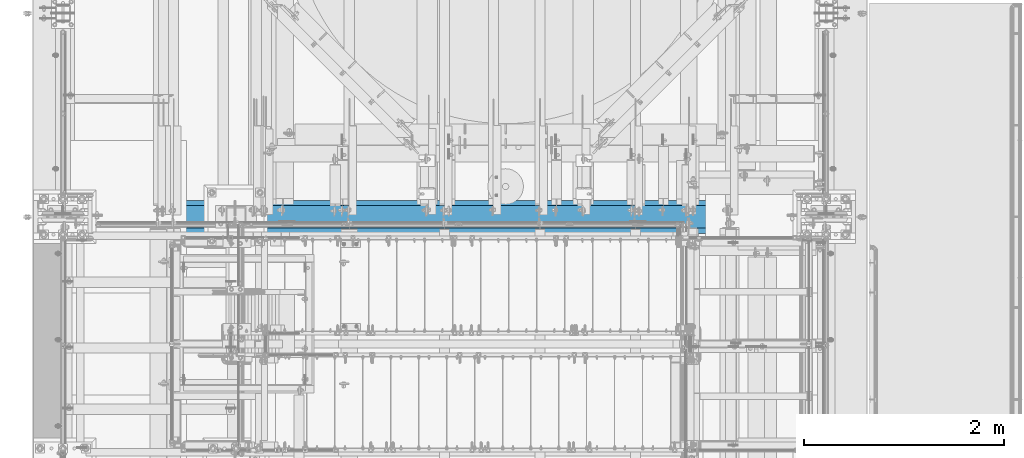
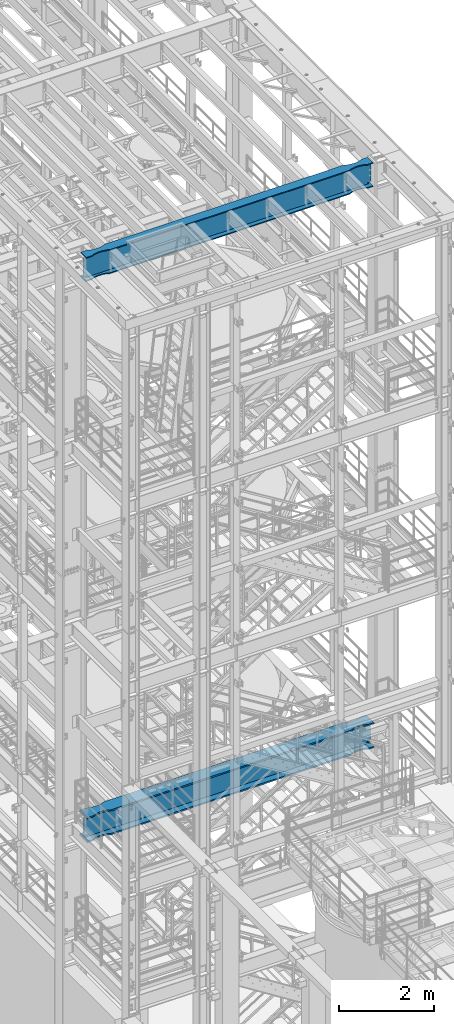
# One storey, part 981 of 1876: 2 beams, 2 elements without a shape of their own.
"""IFC2X3 building model written with IfcOpenShell, lengths in millimetres."""

from ifc_helpers import new_model, si_unit, frame, origin_with_axes, place, context, subcontext, project, spatial, faceted_brep, material, type_object, element, aggregate, save


model = new_model("IFC2X3")

# Units and contexts
model_context = context("Model", 3, precision=1e-05, world=origin_with_axes())
body_context = subcontext(model_context, "Body", "Model", "MODEL_VIEW")
ifc_project = project(units=[si_unit("LENGTHUNIT", "METRE", prefix="MILLI"), si_unit("AREAUNIT", "SQUARE_METRE"), si_unit("VOLUMEUNIT", "CUBIC_METRE"), si_unit("MASSUNIT", "GRAM", prefix="KILO"), si_unit("TIMEUNIT", "SECOND"), si_unit("PLANEANGLEUNIT", "RADIAN"), si_unit("SOLIDANGLEUNIT", "STERADIAN"), si_unit("THERMODYNAMICTEMPERATUREUNIT", "DEGREE_CELSIUS"), si_unit("LUMINOUSINTENSITYUNIT", "LUMEN")], contexts=[model_context])

# Site, building, storey
site_placement = place(None, origin_with_axes())
site = spatial("IfcSite", under=ifc_project, at=site_placement, CompositionType="ELEMENT")
building_placement = place(site_placement, origin_with_axes())
building = spatial("IfcBuilding", under=site, at=building_placement, Name="Undefined", CompositionType="ELEMENT")
storey_placement = place(building_placement, origin_with_axes())
storey = spatial("IfcBuildingStorey", under=building, at=storey_placement, Name="Undefined", CompositionType="ELEMENT", Elevation=0.0)

# Assembly, beam
assembly_1_placement = place(storey_placement, origin_with_axes())
assembly_1 = element("IfcElementAssembly", 1, at=assembly_1_placement, inside=storey, Name="BEAM", AssemblyPlace="NOTDEFINED", PredefinedType="RIGID_FRAME")
ifc_material = material(Name="STEEL/A992")
beam_type_1 = type_object("IfcBeamType", Name="W24X103", PredefinedType="NOTDEFINED")
beam_1_placement = place(assembly_1_placement, frame((0.0, -4572.0, 22244.05), z_axis=(0.0, 0.0, 1.0), x_axis=(1.0, 0.0, 0.0)))
beam_1 = element("IfcBeam", 2, at=beam_1_placement, type_object=beam_type_1, material=ifc_material, Name="BEAM", ObjectType="W24X103", context=body_context, shape_type="Brep", body=[
    faceted_brep([(301.625, 7.14375000000018, -250.825000000001), (309.5625, -7.14375000000018, -250.825000000001), (309.5625, -7.14375000000018, 250.825000000001), (301.625, 7.14375000000018, 250.825000000001), (7318.375, 7.14375000000018, 250.825000000001), (7310.4375, -7.14375000000018, 250.825000000001), (7310.4375, -7.14375000000018, -250.825000000001), (7318.375, 7.14375000000018, -250.825000000001), (7031.26184334843, -69.8863852197028, -285.75), (7031.26184334843, -69.8863852197028, -311.150000000001), (7113.70085269938, -88.8999885500325, -311.150000000001), (7113.70085269938, -88.8999885500325, -285.75), (6946.89999522536, -63.4999969110422, -285.75), (6946.89999522536, -63.4999969110422, -311.150000000001), (6862.53814723751, -69.886387005964, -285.75), (6862.53814723751, -69.886387005964, -311.150000000001), (6780.09913828916, -88.8999920818405, -285.75), (6780.09913828916, -88.8999920818405, -311.150000000001), (6730.99999123786, -114.3, -285.75), (6730.99999123786, -114.3, -311.150000000001), (889.000008761879, -114.300009625518, -285.75), (889.000008761879, -114.3, -311.150000000001), (6730.99999123786, -114.3, 285.75), (6730.99999123786, -114.3, 311.150000000001), (889.000008761879, -114.300009625518, 311.150000000001), (889.000008761879, -114.3, 285.75), (6780.09913828916, -88.8999920818405, 285.75), (6780.09913828916, -88.8999920818405, 311.150000000001), (6862.53814723751, -69.886387005964, 285.75), (6862.53814723751, -69.886387005964, 311.150000000001), (6946.89999522536, -63.4999969110422, 285.75), (6946.89999522536, -63.4999969110422, 311.150000000001), (7031.26184334843, -69.8863852197028, 285.75), (7031.26184334843, -69.8863852197028, 311.150000000001), (7113.70085269938, -88.8999885500325, 285.75), (7113.70085269938, -88.8999885500325, 311.150000000001), (7162.79999999982, -114.299985144468, 311.150000000001), (7162.79999999982, -114.3, 285.75), (7318.375, -114.3, 285.75), (7303.71041369173, -114.299998599709, 311.150000000001), (7269.91500317383, -7.14375000000018, -285.35299987793), (7269.91500317383, 7.14375000000018, -285.35299987793), (7234.44274885072, 7.14375000000018, -269.000062630286), (7234.44274885072, -7.14375000000018, -269.000062630286), (7230.55254094452, 7.14375000000018, -265.703842989446), (7230.55254094452, -7.14375000000018, -265.703842989446), (7228.91987519741, 7.14375000000018, -260.873399528195), (7228.91987519741, -7.14375000000018, -260.873399528195), (7230.01261637614, 7.14375000000018, -255.89296800167), (7230.01261637614, -7.14375000000018, -255.89296800167), (7233.51762316711, 7.14375000000018, -252.189765486371), (7233.51762316711, -7.14375000000018, -252.189765486371), (7238.43048349907, 7.14375000000018, -250.825000000001), (7238.43048349907, -7.14375000000018, -250.825000000001), (7239.26548546451, 7.14375000000018, 250.825000000001), (7239.26548546451, -7.14375000000018, 250.825000000001), (7234.35262519576, 7.14375000000018, 252.189765448315), (7234.35262519576, -7.14375000000018, 252.189765448315), (7230.84761841062, 7.14375000000018, 255.892967871263), (7230.84761841062, -7.14375000000018, 255.892967871263), (7229.75487715069, 7.14375000000018, 260.873399307191), (7229.75487715069, -7.14375000000018, 260.873399307191), (7231.38754274408, 7.14375000000018, 265.703842745359), (7231.38754274408, -7.14375000000018, 265.703842745359), (7235.27775048114, 7.14375000000018, 269.000062475843), (7235.27775048114, -7.14375000000018, 269.000062475843), (7270.75000152588, 7.14375000000018, 285.35299987793), (7270.75000152588, -7.14375000000018, 285.35299987793), (7318.375, 7.14375000000018, 285.35299987793), (7318.375, -7.14375000000018, 285.35299987793), (7318.375, 7.14375000000018, 285.75), (7318.375, -7.14375000000018, 285.75), (6730.99999123786, 114.3, 311.150000000001), (6730.99999123786, 114.3, 285.75), (889.000008761879, 114.3, 285.75), (889.000008761879, 114.299990374482, 311.150000000001), (6780.09913828916, 88.9000064541397, 311.150000000001), (6780.09913828916, 88.9000064541397, 285.75), (6862.53814723751, 69.8864013782631, 311.150000000001), (6862.53814723751, 69.8864013782631, 285.75), (6946.89999522536, 63.5000112833413, 311.150000000001), (6946.89999522536, 63.5000112833413, 285.75), (7031.26184334843, 69.8863995920019, 311.150000000001), (7031.26184334843, 69.8863995920019, 285.75), (7113.70085269938, 88.9000029223316, 311.150000000001), (7113.70085269938, 88.9000029223316, 285.75), (7162.79999999982, 114.299999516767, 311.150000000001), (7162.79999999982, 114.3, 285.75), (7303.71041369173, 114.29999995445, 311.150000000001), (7318.375, 114.3, 285.75), (301.625, 7.14375000000018, 285.75), (301.625, 114.3, 285.75), (457.200000000009, 114.3, 285.75), (506.299147300449, 88.899986110664, 285.75), (588.738156651386, 69.8863827803343, 285.75), (673.100004774441, 63.4999944716737, 285.75), (757.461852762268, 69.8863845665956, 285.75), (839.9008617106, 88.8999896424721, 285.75), (457.200000000009, 114.3, 311.150000000001), (316.289586308271, 114.3, 311.150000000001), (506.299147300449, 88.899986110664, 311.150000000001), (588.738156651386, 69.8863827803343, 311.150000000001), (673.100004774441, 63.4999944716737, 311.150000000001), (757.461852762268, 69.8863845665956, 311.150000000001), (839.9008617106, 88.8999896424721, 311.150000000001), (316.289586308271, -114.3, 311.150000000001), (457.200000000009, -114.3, 311.150000000001), (506.299147300449, -88.9000053617001, 311.150000000001), (588.738156651386, -69.8864020313704, 311.150000000001), (673.100004774441, -63.5000137227098, 311.150000000001), (757.461852762268, -69.8864038176316, 311.150000000001), (839.9008617106, -88.9000088935081, 311.150000000001), (457.200000000009, -114.3, 285.75), (301.625, -114.3, 285.75), (506.299147300449, -88.9000053617001, 285.75), (588.738156651386, -69.8864020313704, 285.75), (673.100004774441, -63.5000137227098, 285.75), (757.461852762268, -69.8864038176316, 285.75), (839.9008617106, -88.9000088935081, 285.75), (301.625, -7.14375000000018, 285.75), (301.625, 7.14375000000018, 285.35299987793), (301.625, -7.14375000000018, 285.35299987793), (349.249998474121, 7.14375000000018, 285.35299987793), (349.249998474121, -7.14375000000018, 285.35299987793), (384.722249518856, 7.14375000000018, 269.000062475843), (384.722249518856, -7.14375000000018, 269.000062475843), (388.612457255921, 7.14375000000018, 265.703842745359), (388.612457255921, -7.14375000000018, 265.703842745359), (390.245122849314, 7.14375000000018, 260.873399307191), (390.245122849314, -7.14375000000018, 260.873399307191), (389.152381589376, 7.14375000000018, 255.892967871263), (389.152381589376, -7.14375000000018, 255.892967871263), (385.647374804242, 7.14375000000018, 252.189765448315), (385.647374804242, -7.14375000000018, 252.189765448315), (380.734514535493, 7.14375000000018, 250.825000000001), (380.734514535493, -7.14375000000018, 250.825000000001), (381.56951650093, 7.14375000000018, -250.825000000001), (381.56951650093, -7.14375000000018, -250.825000000001), (386.482376832887, 7.14375000000018, -252.189765486371), (386.482376832887, -7.14375000000018, -252.189765486371), (389.98738362386, 7.14375000000018, -255.89296800167), (389.98738362386, -7.14375000000018, -255.89296800167), (391.080124802588, 7.14375000000018, -260.873399528195), (391.080124802588, -7.14375000000018, -260.873399528195), (389.447459055476, 7.14375000000018, -265.703842989446), (389.447459055476, -7.14375000000018, -265.703842989446), (385.557251149282, 7.14375000000018, -269.000062630286), (385.557251149282, -7.14375000000018, -269.000062630286), (350.084996826172, 7.14375000000018, -285.35299987793), (350.084996826172, -7.14375000000018, -285.35299987793), (316.518799385621, 7.14375000000018, -285.35299987793), (316.518799385621, -7.14375000000018, -285.35299987793), (316.28959905754, -7.14375000000018, -285.75), (7303.71040094246, -7.14375000000018, -285.75), (7303.48120061438, -7.14375000000018, -285.35299987793), (7303.48120061438, 7.14375000000018, -285.35299987793), (316.28959905754, 7.14375000000018, -285.75), (7303.71040094246, 7.14375000000018, -285.75), (316.28959905754, 114.3, -285.75), (301.625, 114.3, -311.150000000001), (301.625, -114.3, -311.150000000001), (316.28959905754, -114.3, -285.75), (457.200000000009, -114.3, -311.150000000001), (457.200000000009, -114.3, -285.75), (506.299147300449, -88.9000053617001, -311.150000000001), (506.299147300449, -88.9000053617001, -285.75), (588.738156651386, -69.8864020313704, -311.150000000001), (588.738156651386, -69.8864020313704, -285.75), (673.100004774441, -63.5000137227098, -311.150000000001), (673.100004774441, -63.5000137227098, -285.75), (757.461852762268, -69.8864038176316, -311.150000000001), (757.461852762268, -69.8864038176316, -285.75), (839.9008617106, -88.9000088935081, -311.150000000001), (839.9008617106, -88.9000088935081, -285.75), (7162.79999999982, -114.299985144468, -285.75), (7303.71040094246, -114.299998599708, -285.75), (7318.375, -114.3, -311.150000000001), (7318.375, 114.3, -311.150000000001), (7303.71040094246, 114.29999995445, -285.75), (7162.79999999982, 114.3, -311.150000000001), (7162.79999999982, 114.299999516767, -285.75), (7113.70085269938, 88.9000029223316, -311.150000000001), (7113.70085269938, 88.9000029223316, -285.75), (7031.26184334843, 69.8863995920019, -311.150000000001), (7031.26184334843, 69.8863995920019, -285.75), (6946.89999522536, 63.5000112833413, -311.150000000001), (6946.89999522536, 63.5000112833413, -285.75), (6862.53814723751, 69.8864013782631, -311.150000000001), (6862.53814723751, 69.8864013782631, -285.75), (6780.09913828916, 88.9000064541397, -311.150000000001), (6780.09913828916, 88.9000064541397, -285.75), (6730.99999123786, 114.3, -311.150000000001), (6730.99999123786, 114.3, -285.75), (889.000008761879, 114.3, -311.150000000001), (889.000008761879, 114.299990374482, -285.75), (839.9008617106, 88.8999896424721, -285.75), (757.461852762268, 69.8863845665956, -285.75), (673.100004774441, 63.4999944716737, -285.75), (588.738156651386, 69.8863827803343, -285.75), (506.299147300449, 88.899986110664, -285.75), (457.200000000009, 114.3, -285.75), (457.200000000009, 114.3, -311.150000000001), (506.299147300449, 88.899986110664, -311.150000000001), (588.738156651386, 69.8863827803343, -311.150000000001), (673.100004774441, 63.4999944716737, -311.150000000001), (757.461852762268, 69.8863845665956, -311.150000000001), (839.9008617106, 88.8999896424721, -311.150000000001), (7162.79999999982, -114.3, -311.150000000001)], [[[0, 1, 2, 3]], [[4, 5, 6, 7]], [[8, 9, 10, 11]], [[12, 13, 9, 8]], [[14, 15, 13, 12]], [[16, 17, 15, 14]], [[18, 19, 17, 16]], [[19, 18, 20, 21]], [[22, 23, 24, 25]], [[23, 22, 26, 27]], [[27, 26, 28, 29]], [[29, 28, 30, 31]], [[31, 30, 32, 33]], [[33, 32, 34, 35]], [[36, 35, 34, 37]], [[36, 37, 38, 39]], [[40, 41, 42, 43]], [[43, 42, 44, 45]], [[45, 44, 46, 47]], [[47, 46, 48, 49]], [[49, 48, 50, 51]], [[51, 50, 52, 53]], [[53, 52, 7, 6]], [[54, 55, 5, 4]], [[55, 54, 56, 57]], [[57, 56, 58, 59]], [[59, 58, 60, 61]], [[61, 60, 62, 63]], [[63, 62, 64, 65]], [[65, 64, 66, 67]], [[67, 66, 68, 69]], [[69, 68, 70, 71]], [[72, 73, 74, 75]], [[76, 77, 73, 72]], [[78, 79, 77, 76]], [[80, 81, 79, 78]], [[82, 83, 81, 80]], [[84, 85, 83, 82]], [[86, 87, 85, 84]], [[87, 86, 88, 89]], [[38, 71, 70, 89, 88, 39]], [[90, 91, 92, 93, 94, 95, 96, 97, 74, 73, 77, 79, 81, 83, 85, 87, 89, 70]], [[98, 92, 91, 99]], [[100, 93, 92, 98]], [[101, 94, 93, 100]], [[102, 95, 94, 101]], [[103, 96, 95, 102]], [[104, 97, 96, 103]], [[75, 74, 97, 104]], [[86, 84, 82, 80, 78, 76, 72, 75, 104, 103, 102, 101, 100, 98, 99, 105, 106, 107, 108, 109, 110, 111, 24, 23, 27, 29, 31, 33, 35, 36, 39, 88]], [[112, 106, 105, 113]], [[106, 112, 114, 107]], [[107, 114, 115, 108]], [[108, 115, 116, 109]], [[109, 116, 117, 110]], [[110, 117, 118, 111]], [[24, 111, 118, 25]], [[37, 34, 32, 30, 28, 26, 22, 25, 118, 117, 116, 115, 114, 112, 113, 119, 71, 38]], [[105, 99, 91, 90, 119, 113]], [[120, 121, 119, 90]], [[122, 123, 121, 120]], [[123, 122, 124, 125]], [[125, 124, 126, 127]], [[127, 126, 128, 129]], [[129, 128, 130, 131]], [[131, 130, 132, 133]], [[133, 132, 134, 135]], [[135, 134, 3, 2]], [[136, 137, 1, 0]], [[137, 136, 138, 139]], [[139, 138, 140, 141]], [[141, 140, 142, 143]], [[143, 142, 144, 145]], [[145, 144, 146, 147]], [[147, 146, 148, 149]], [[149, 148, 150, 151]], [[137, 139, 141, 143, 145, 147, 149, 151, 152, 153, 154, 40, 43, 45, 47, 49, 51, 53, 6, 5, 55, 57, 59, 61, 63, 65, 67, 69, 71, 119, 121, 123, 125, 127, 129, 131, 133, 135, 2, 1]], [[41, 40, 154, 155]], [[156, 150, 148, 146, 144, 142, 140, 138, 136, 0, 3, 134, 132, 130, 128, 126, 124, 122, 120, 90, 70, 68, 66, 64, 62, 60, 58, 56, 54, 4, 7, 52, 50, 48, 46, 44, 42, 41, 155, 157]], [[151, 150, 156, 158, 159, 160, 161, 152]], [[162, 163, 161, 160]], [[163, 162, 164, 165]], [[165, 164, 166, 167]], [[167, 166, 168, 169]], [[169, 168, 170, 171]], [[171, 170, 172, 173]], [[20, 173, 172, 21]], [[152, 161, 163, 165, 167, 169, 171, 173, 20, 18, 16, 14, 12, 8, 11, 174, 175, 153]], [[176, 177, 178, 157, 155, 154, 153, 175]], [[179, 180, 178, 177]], [[180, 179, 181, 182]], [[182, 181, 183, 184]], [[184, 183, 185, 186]], [[186, 185, 187, 188]], [[188, 187, 189, 190]], [[190, 189, 191, 192]], [[192, 191, 193, 194]], [[180, 182, 184, 186, 188, 190, 192, 194, 195, 196, 197, 198, 199, 200, 158, 156, 157, 178]], [[200, 201, 159, 158]], [[199, 202, 201, 200]], [[198, 203, 202, 199]], [[197, 204, 203, 198]], [[196, 205, 204, 197]], [[195, 206, 205, 196]], [[194, 193, 206, 195]], [[207, 10, 9, 13, 15, 17, 19, 21, 172, 170, 168, 166, 164, 162, 160, 159, 201, 202, 203, 204, 205, 206, 193, 191, 189, 187, 185, 183, 181, 179, 177, 176]], [[174, 11, 10, 207]], [[174, 207, 176, 175]]]),
])
aggregate(assembly_1, [beam_1])

assembly_2_placement = place(storey_placement, origin_with_axes())
assembly_2 = element("IfcElementAssembly", 3, at=assembly_2_placement, inside=storey, Name="BEAM", AssemblyPlace="NOTDEFINED", PredefinedType="RIGID_FRAME")
beam_type_2 = type_object("IfcBeamType", Name="W24X192", PredefinedType="NOTDEFINED")
beam_2_placement = place(assembly_2_placement, frame((0.0, -4572.0, 7829.55), z_axis=(0.0, 0.0, 1.0), x_axis=(1.0, 0.0, 0.0)))
beam_2 = element("IfcBeam", 4, at=beam_2_placement, type_object=beam_type_2, material=ifc_material, Name="BEAM", ObjectType="W24X192", context=body_context, shape_type="Brep", body=[
    faceted_brep([(301.625, 10.3187500000004, -234.9495), (314.325, -10.3187500000004, -234.9495), (314.325, -10.3187500000004, 234.9495), (301.625, 10.3187500000004, 234.9495), (7318.375, 10.3187500000004, 234.9495), (7305.675, -10.3187500000004, 234.9495), (7305.675, -10.3187500000004, -234.9495), (7318.375, 10.3187500000004, -234.9495), (7318.375, -165.1, 287.3375), (7318.375, -10.3187500000004, 287.3375), (7318.375, 10.3187500000004, 287.3375), (7318.375, 165.1, 287.3375), (7297.29441686758, 165.10000015544, 323.85), (7297.29441686758, -165.10000015544, 323.85), (7162.79999999997, 165.100001147153, 323.85), (7162.79999999997, 165.1, 287.3375), (7106.74278259149, 137.743354635527, 287.3375), (7106.74278259149, 137.743354635527, 323.85), (7106.31195150567, 137.548767822031, 287.3375), (7106.31195150567, 137.548767822031, 323.85), (7105.87030058721, 137.380173875744, 287.3375), (7105.87030058721, 137.380173875744, 323.85), (7105.41939640416, 137.238170811695, 287.3375), (7105.41939640416, 137.238170811695, 323.85), (7104.96083834654, 137.123262325114, 287.3375), (7104.96083834654, 137.123262325114, 323.85), (7027.22388047199, 120.086541102203, 287.3375), (7027.22388047199, 120.086541102203, 323.85), (6946.89999542258, 114.300000048446, 287.3375), (6946.89999542258, 114.300000048446, 323.85), (6866.57611029489, 120.086540015548, 287.3375), (6866.57611029489, 120.086540015548, 323.85), (6787.91106783742, 137.326657821507, 287.3375), (6787.91106783742, 137.326657821507, 323.85), (6731.00000871489, 165.1, 287.3375), (6731.00000871489, 165.100000403941, 323.85), (888.999990590519, 165.1, 287.3375), (888.999990590519, 165.100004421514, 323.85), (832.088931467987, 137.326657821507, 287.3375), (832.088931467987, 137.326657821507, 323.85), (753.423889010533, 120.086540015548, 287.3375), (753.423889010533, 120.086540015548, 323.85), (673.100003882856, 114.300000048446, 287.3375), (673.100003882856, 114.300000048446, 323.85), (592.776118833464, 120.086541102203, 287.3375), (592.776118833464, 120.086541102203, 323.85), (515.039160958935, 137.123262325114, 287.3375), (515.039160958935, 137.123262325114, 323.85), (514.580602901315, 137.238170811695, 287.3375), (514.580602901315, 137.238170811695, 323.85), (514.12969871826, 137.380173875744, 287.3375), (514.12969871826, 137.380173875744, 323.85), (513.688047799806, 137.548767822031, 287.3375), (513.688047799806, 137.548767822031, 323.85), (513.257216713985, 137.743354635527, 287.3375), (513.257216713985, 137.743354635527, 323.85), (457.199999305522, 165.1, 287.3375), (457.199999305522, 165.1, 323.85), (301.625, 165.1, 287.3375), (322.705583132423, 165.1, 323.85), (7162.79999999997, 165.100001147153, -287.3375), (7162.79999999997, 165.1, -323.85), (7106.74278259149, 137.743354635527, -323.85), (7106.74278259149, 137.743354635527, -287.3375), (7106.31195150567, 137.548767822031, -323.85), (7106.31195150567, 137.548767822031, -287.3375), (7105.87030058721, 137.380173875744, -323.85), (7105.87030058721, 137.380173875744, -287.3375), (7105.41939640416, 137.238170811695, -323.85), (7105.41939640416, 137.238170811695, -287.3375), (7104.96083834654, 137.123262325114, -323.85), (7104.96083834654, 137.123262325114, -287.3375), (7027.22388047199, 120.086541102203, -323.85), (7027.22388047199, 120.086541102203, -287.3375), (6946.89999542258, 114.300000048446, -323.85), (6946.89999542258, 114.300000048446, -287.3375), (6866.57611029489, 120.086540015548, -323.85), (6866.57611029489, 120.086540015548, -287.3375), (6787.91106783742, 137.326657821507, -323.85), (6787.91106783742, 137.326657821507, -287.3375), (6731.00000871489, 165.1, -323.85), (6731.00000871489, 165.100000403941, -287.3375), (888.999990590519, 165.1, -323.85), (888.999990590519, 165.100004421514, -287.337500000001), (832.088931467987, 137.326657821507, -323.85), (832.088931467987, 137.326657821507, -287.3375), (753.423889010533, 120.086540015548, -323.85), (753.423889010533, 120.086540015548, -287.3375), (673.100003882856, 114.300000048446, -323.85), (673.100003882856, 114.300000048446, -287.3375), (592.776118833464, 120.086541102203, -323.85), (592.776118833464, 120.086541102203, -287.3375), (515.039160958935, 137.123262325114, -323.85), (515.039160958935, 137.123262325114, -287.3375), (514.580602901315, 137.238170811695, -323.85), (514.580602901315, 137.238170811695, -287.3375), (514.12969871826, 137.380173875744, -323.85), (514.12969871826, 137.380173875744, -287.3375), (513.688047799806, 137.548767822031, -323.85), (513.688047799806, 137.548767822031, -287.3375), (513.257216713985, 137.743354635527, -323.85), (513.257216713985, 137.743354635527, -287.3375), (457.199999305522, 165.1, -323.85), (457.199999305522, 165.1, -287.3375), (301.625, 165.1, -323.85), (322.705590767972, 165.1, -287.3375), (7162.79999999997, -165.100001147153, -287.3375), (7106.74278259149, -137.743354635527, -287.3375), (7106.74278259149, -137.743354635527, -323.85), (7162.79999999997, -165.1, -323.85), (7106.31195150567, -137.548767822031, -287.3375), (7106.31195150567, -137.548767822031, -323.85), (7105.87030058721, -137.380173875744, -287.3375), (7105.87030058721, -137.380173875744, -323.85), (7105.41939640416, -137.238170811695, -287.3375), (7105.41939640416, -137.238170811695, -323.85), (7104.96083834654, -137.123262325114, -287.3375), (7104.96083834654, -137.123262325114, -323.85), (7027.22388047199, -120.086541102203, -287.3375), (7027.22388047199, -120.086541102203, -323.85), (6946.89999542258, -114.300000048446, -287.3375), (6946.89999542258, -114.300000048446, -323.85), (6866.57611029489, -120.086540015548, -287.3375), (6866.57611029489, -120.086540015548, -323.85), (6787.91106783742, -137.326657821507, -287.3375), (6787.91106783742, -137.326657821507, -323.85), (6731.00000871489, -165.100000403941, -287.3375), (6731.00000871489, -165.1, -323.85), (888.999990590519, -165.100004421514, -287.3375), (888.999990590519, -165.1, -323.85), (832.088931467987, -137.326657821507, -287.3375), (832.088931467987, -137.326657821507, -323.85), (753.423889010533, -120.086540015548, -287.3375), (753.423889010533, -120.086540015548, -323.85), (673.100003882856, -114.300000048446, -287.3375), (673.100003882856, -114.300000048446, -323.85), (592.776118833464, -120.086541102203, -287.3375), (592.776118833464, -120.086541102203, -323.85), (515.039160958935, -137.123262325114, -287.3375), (515.039160958935, -137.123262325114, -323.85), (514.580602901315, -137.238170811695, -287.3375), (514.580602901315, -137.238170811695, -323.85), (514.12969871826, -137.380173875744, -287.3375), (514.12969871826, -137.380173875744, -323.85), (513.688047799806, -137.548767822031, -287.3375), (513.688047799806, -137.548767822031, -323.85), (513.257216713985, -137.743354635527, -287.3375), (513.257216713985, -137.743354635527, -323.85), (457.199999305522, -165.1, -287.3375), (457.199999305522, -165.1, -323.85), (322.705590767972, -165.1, -287.3375), (301.625, -165.1, -323.85), (322.934794701563, -10.3187500000004, -286.94050112915), (322.934794701563, 10.3187500000004, -286.94050112915), (322.705590767971, 10.3187500000004, -287.3375), (322.705590767971, -10.3187500000004, -287.3375), (346.976999328614, -10.3187500000004, -286.94050112915), (346.976999328614, 10.3187500000004, -286.94050112915), (420.061565494404, -10.3187500000004, -253.118738544442), (420.061565494404, 10.3187500000004, -253.118738544442), (423.945404365968, -10.3187500000004, -249.819149292641), (423.945404365968, 10.3187500000004, -249.819149292641), (425.572284211328, -10.3187500000004, -244.98957834072), (425.572284211328, 10.3187500000004, -244.98957834072), (424.476487622709, -10.3187500000004, -240.012558806176), (424.476487622709, 10.3187500000004, -240.012558806176), (420.97170190047, -10.3187500000004, -236.312833052547), (420.97170190047, 10.3187500000004, -236.312833052547), (416.061221618592, -10.3187500000004, -234.9495), (416.061221618592, 10.3187500000004, -234.9495), (415.15921904546, -10.3187500000004, 234.949499999999), (415.15921904546, 10.3187500000004, 234.949499999999), (420.069699306212, -10.3187500000004, 236.312833039836), (420.069699306212, 10.3187500000004, 236.312833039836), (423.574485026478, -10.3187500000004, 240.012558762611), (423.574485026478, 10.3187500000004, 240.012558762611), (424.670281642195, -10.3187500000004, 244.989578266865), (424.670281642195, 10.3187500000004, 244.989578266865), (423.043401848172, -10.3187500000004, 249.819149211012), (423.043401848172, 10.3187500000004, 249.819149211012), (419.159563033145, -10.3187500000004, 253.11873849267), (419.159563033145, 10.3187500000004, 253.11873849267), (346.074999237061, -10.3187500000004, 286.94050112915), (346.074999237061, 10.3187500000004, 286.94050112915), (301.625, -10.3187500000004, 286.94050112915), (301.625, 10.3187500000004, 286.94050112915), (301.625, -10.3187500000004, 287.3375), (301.625, 10.3187500000004, 287.3375), (322.705583132423, -165.1, 323.85), (301.625, -165.1, 287.3375), (457.199999305522, -165.1, 287.3375), (457.199999305522, -165.1, 323.85), (513.257216713985, -137.743354635527, 287.3375), (513.257216713985, -137.743354635527, 323.85), (513.688047799806, -137.548767822031, 287.3375), (513.688047799806, -137.548767822031, 323.85), (514.12969871826, -137.380173875744, 287.3375), (514.12969871826, -137.380173875744, 323.85), (514.580602901315, -137.238170811695, 287.3375), (514.580602901315, -137.238170811695, 323.85), (515.039160958935, -137.123262325114, 287.3375), (515.039160958935, -137.123262325114, 323.85), (592.776118833464, -120.086541102203, 287.3375), (592.776118833464, -120.086541102203, 323.85), (673.100003882856, -114.300000048446, 287.3375), (673.100003882856, -114.300000048446, 323.85), (753.423889010533, -120.086540015548, 287.3375), (753.423889010533, -120.086540015548, 323.85), (832.088931467987, -137.326657821507, 287.3375), (832.088931467987, -137.326657821507, 323.85), (888.999990590519, -165.100004421514, 323.85), (888.999990590519, -165.1, 287.3375), (6731.00000871489, -165.1, 287.3375), (6731.00000871489, -165.100000403941, 323.85), (6787.91106783742, -137.326657821507, 287.3375), (6787.91106783742, -137.326657821507, 323.85), (6866.57611029489, -120.086540015548, 287.3375), (6866.57611029489, -120.086540015548, 323.85), (6946.89999542258, -114.300000048446, 287.3375), (6946.89999542258, -114.300000048446, 323.85), (7027.22388047199, -120.086541102203, 287.3375), (7027.22388047199, -120.086541102203, 323.85), (7104.96083834654, -137.123262325114, 287.3375), (7104.96083834654, -137.123262325114, 323.85), (7105.41939640416, -137.238170811695, 287.3375), (7105.41939640416, -137.238170811695, 323.85), (7105.87030058721, -137.380173875744, 287.3375), (7105.87030058721, -137.380173875744, 323.85), (7106.31195150567, -137.548767822031, 287.3375), (7106.31195150567, -137.548767822031, 323.85), (7106.74278259149, -137.743354635527, 287.3375), (7106.74278259149, -137.743354635527, 323.85), (7162.79999999997, -165.100001147153, 323.85), (7162.79999999997, -165.1, 287.3375), (7318.375, -10.3187500000004, 286.94050112915), (7318.375, 10.3187500000004, 286.94050112915), (7273.92500076294, -10.3187500000004, 286.94050112915), (7273.92500076294, 10.3187500000004, 286.94050112915), (7200.84043696685, -10.3187500000004, 253.118738492671), (7200.84043696685, 10.3187500000004, 253.118738492671), (7196.95659815183, -10.3187500000004, 249.819149211013), (7196.95659815183, 10.3187500000004, 249.819149211013), (7195.3297183578, -10.3187500000004, 244.989578266866), (7195.3297183578, 10.3187500000004, 244.989578266866), (7196.42551497352, -10.3187500000004, 240.012558762612), (7196.42551497352, 10.3187500000004, 240.012558762612), (7199.93030069379, -10.3187500000004, 236.312833039837), (7199.93030069379, 10.3187500000004, 236.312833039837), (7204.84078095454, -10.3187500000004, 234.9495), (7204.84078095454, 10.3187500000004, 234.9495), (7203.93877838141, -10.3187500000004, -234.9495), (7203.93877838141, 10.3187500000004, -234.9495), (7199.02829809953, -10.3187500000004, -236.312833052547), (7199.02829809953, 10.3187500000004, -236.312833052547), (7195.52351237729, -10.3187500000004, -240.012558806176), (7195.52351237729, 10.3187500000004, -240.012558806176), (7194.42771578867, -10.3187500000004, -244.98957834072), (7194.42771578867, 10.3187500000004, -244.98957834072), (7196.05459563403, -10.3187500000004, -249.819149292641), (7196.05459563403, 10.3187500000004, -249.819149292641), (7199.93843450559, -10.3187500000004, -253.118738544442), (7199.93843450559, 10.3187500000004, -253.118738544442), (7273.02300067138, -10.3187500000004, -286.94050112915), (7273.02300067138, 10.3187500000004, -286.94050112915), (7297.06520529844, -10.3187500000004, -286.94050112915), (7297.06520529844, 10.3187500000004, -286.94050112915), (7297.29440923203, 10.3187500000004, -287.3375), (7297.29440923203, 165.10000015544, -287.3375), (7318.375, 165.1, -323.85), (7318.375, -165.1, -323.85), (7297.29440923203, -165.10000015544, -287.3375), (7297.29440923203, -10.3187500000004, -287.3375)], [[[0, 1, 2, 3]], [[4, 5, 6, 7]], [[8, 9, 10, 11, 12, 13]], [[14, 15, 16, 17]], [[17, 16, 18, 19]], [[19, 18, 20, 21]], [[21, 20, 22, 23]], [[23, 22, 24, 25]], [[25, 24, 26, 27]], [[27, 26, 28, 29]], [[29, 28, 30, 31]], [[31, 30, 32, 33]], [[33, 32, 34, 35]], [[36, 37, 35, 34]], [[37, 36, 38, 39]], [[39, 38, 40, 41]], [[41, 40, 42, 43]], [[43, 42, 44, 45]], [[45, 44, 46, 47]], [[47, 46, 48, 49]], [[49, 48, 50, 51]], [[51, 50, 52, 53]], [[53, 52, 54, 55]], [[55, 54, 56, 57]], [[57, 56, 58, 59]], [[60, 61, 62, 63]], [[63, 62, 64, 65]], [[65, 64, 66, 67]], [[67, 66, 68, 69]], [[69, 68, 70, 71]], [[71, 70, 72, 73]], [[73, 72, 74, 75]], [[75, 74, 76, 77]], [[77, 76, 78, 79]], [[79, 78, 80, 81]], [[82, 83, 81, 80]], [[83, 82, 84, 85]], [[85, 84, 86, 87]], [[87, 86, 88, 89]], [[89, 88, 90, 91]], [[91, 90, 92, 93]], [[93, 92, 94, 95]], [[95, 94, 96, 97]], [[97, 96, 98, 99]], [[99, 98, 100, 101]], [[101, 100, 102, 103]], [[103, 102, 104, 105]], [[106, 107, 108, 109]], [[110, 111, 108, 107]], [[112, 113, 111, 110]], [[114, 115, 113, 112]], [[116, 117, 115, 114]], [[118, 119, 117, 116]], [[120, 121, 119, 118]], [[122, 123, 121, 120]], [[124, 125, 123, 122]], [[126, 127, 125, 124]], [[128, 129, 127, 126]], [[128, 130, 131, 129]], [[132, 133, 131, 130]], [[134, 135, 133, 132]], [[136, 137, 135, 134]], [[138, 139, 137, 136]], [[140, 141, 139, 138]], [[142, 143, 141, 140]], [[144, 145, 143, 142]], [[146, 147, 145, 144]], [[148, 149, 147, 146]], [[149, 148, 150, 151]], [[152, 153, 154, 105, 104, 151, 150, 155]], [[156, 157, 153, 152]], [[158, 159, 157, 156]], [[160, 161, 159, 158]], [[162, 163, 161, 160]], [[164, 165, 163, 162]], [[166, 167, 165, 164]], [[168, 169, 167, 166]], [[169, 168, 1, 0]], [[170, 171, 3, 2]], [[172, 173, 171, 170]], [[174, 175, 173, 172]], [[176, 177, 175, 174]], [[178, 179, 177, 176]], [[180, 181, 179, 178]], [[182, 183, 181, 180]], [[183, 182, 184, 185]], [[185, 184, 186, 187]], [[188, 59, 58, 187, 186, 189]], [[190, 191, 188, 189]], [[191, 190, 192, 193]], [[193, 192, 194, 195]], [[195, 194, 196, 197]], [[197, 196, 198, 199]], [[199, 198, 200, 201]], [[201, 200, 202, 203]], [[203, 202, 204, 205]], [[205, 204, 206, 207]], [[207, 206, 208, 209]], [[210, 209, 208, 211]], [[210, 211, 212, 213]], [[213, 212, 214, 215]], [[215, 214, 216, 217]], [[217, 216, 218, 219]], [[219, 218, 220, 221]], [[221, 220, 222, 223]], [[223, 222, 224, 225]], [[225, 224, 226, 227]], [[227, 226, 228, 229]], [[229, 228, 230, 231]], [[232, 231, 230, 233]], [[232, 233, 8, 13]], [[14, 17, 19, 21, 23, 25, 27, 29, 31, 33, 35, 37, 39, 41, 43, 45, 47, 49, 51, 53, 55, 57, 59, 188, 191, 193, 195, 197, 199, 201, 203, 205, 207, 209, 210, 213, 215, 217, 219, 221, 223, 225, 227, 229, 231, 232, 13, 12]], [[15, 14, 12, 11]], [[187, 58, 56, 54, 52, 50, 48, 46, 44, 42, 40, 38, 36, 34, 32, 30, 28, 26, 24, 22, 20, 18, 16, 15, 11, 10]], [[234, 235, 10, 9]], [[236, 237, 235, 234]], [[238, 239, 237, 236]], [[240, 241, 239, 238]], [[242, 243, 241, 240]], [[244, 245, 243, 242]], [[246, 247, 245, 244]], [[248, 249, 247, 246]], [[249, 248, 5, 4]], [[250, 251, 7, 6]], [[252, 253, 251, 250]], [[254, 255, 253, 252]], [[256, 257, 255, 254]], [[258, 259, 257, 256]], [[260, 261, 259, 258]], [[262, 263, 261, 260]], [[263, 262, 264, 265]], [[154, 153, 157, 159, 161, 163, 165, 167, 169, 0, 3, 171, 173, 175, 177, 179, 181, 183, 185, 187, 10, 235, 237, 239, 241, 243, 245, 247, 249, 4, 7, 251, 253, 255, 257, 259, 261, 263, 265, 266]], [[60, 63, 65, 67, 69, 71, 73, 75, 77, 79, 81, 83, 85, 87, 89, 91, 93, 95, 97, 99, 101, 103, 105, 154, 266, 267]], [[61, 60, 267, 268]], [[109, 108, 111, 113, 115, 117, 119, 121, 123, 125, 127, 129, 131, 133, 135, 137, 139, 141, 143, 145, 147, 149, 151, 104, 102, 100, 98, 96, 94, 92, 90, 88, 86, 84, 82, 80, 78, 76, 74, 72, 70, 68, 66, 64, 62, 61, 268, 269]], [[106, 109, 269, 270]], [[155, 150, 148, 146, 144, 142, 140, 138, 136, 134, 132, 130, 128, 126, 124, 122, 120, 118, 116, 114, 112, 110, 107, 106, 270, 271]], [[269, 268, 267, 266, 265, 264, 271, 270]], [[168, 166, 164, 162, 160, 158, 156, 152, 155, 271, 264, 262, 260, 258, 256, 254, 252, 250, 6, 5, 248, 246, 244, 242, 240, 238, 236, 234, 9, 186, 184, 182, 180, 178, 176, 174, 172, 170, 2, 1]], [[233, 230, 228, 226, 224, 222, 220, 218, 216, 214, 212, 211, 208, 206, 204, 202, 200, 198, 196, 194, 192, 190, 189, 186, 9, 8]]]),
])
aggregate(assembly_2, [beam_2])

save(model, "model.ifc")
